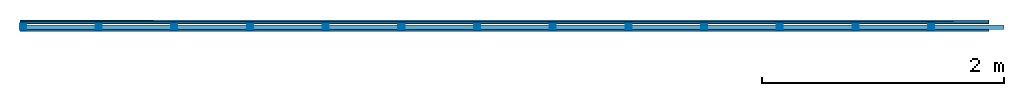
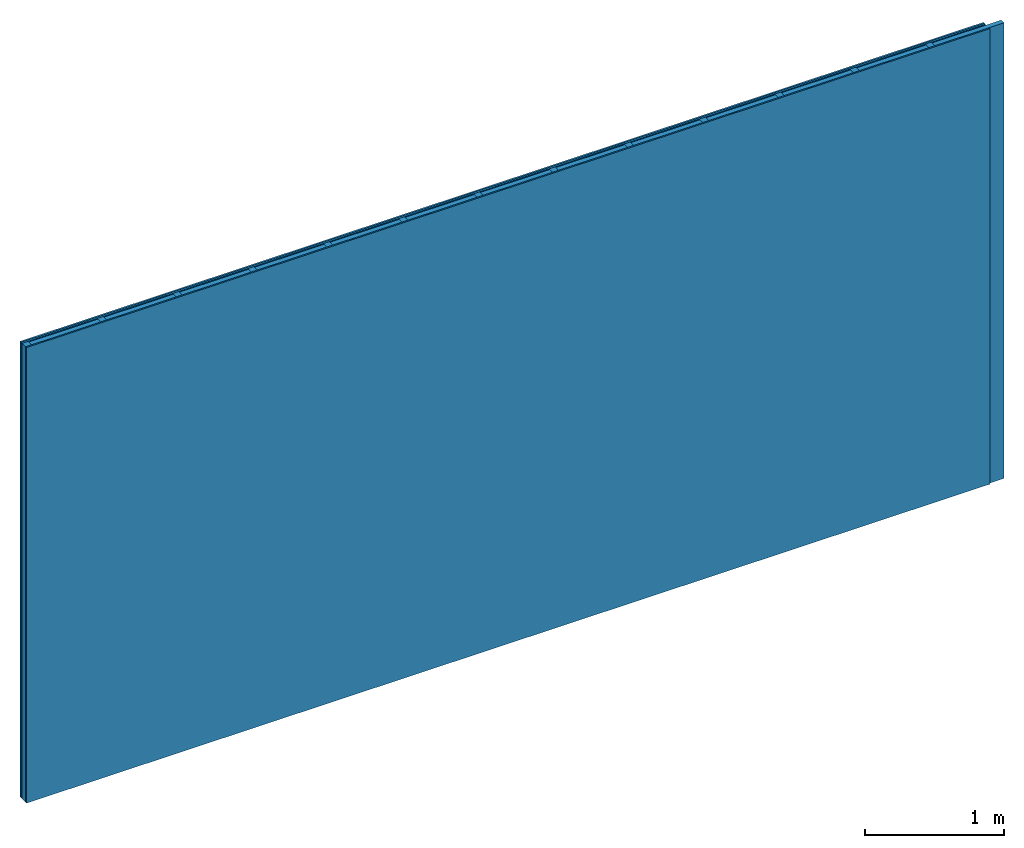
# One storey: 3 plates, 2 members, 1 element without a shape of its own.
"""IFC4 building model written with IfcOpenShell, lengths in metres."""

from ifc_helpers import new_model, si_unit, derived_unit, direction, frame, frame_2d, origin, origin_with_axes, place, context, project, spatial, rectangle, extrude, material, layer, layer_set, type_object, element, aggregate, save


model = new_model("IFC4")

# Units and contexts
plan_context = context("Plan", 3, precision=1e-05, world=origin(), true_north=direction((0.0, 1.0)))
model_context = context("Model", 3, precision=1e-05, world=origin(), true_north=direction((0.0, 1.0)))
ifc_project = project(units=[si_unit("LENGTHUNIT", "METRE"), derived_unit("SOUNDPRESSUREUNIT", [(si_unit("PRESSUREUNIT", "PASCAL", prefix="MICRO"), 0)]), si_unit("ENERGYUNIT", "JOULE", prefix="MEGA"), si_unit("MASSUNIT", "GRAM", prefix="KILO"), derived_unit("THERMALTRANSMITTANCEUNIT", [(si_unit("POWERUNIT", "WATT"), 1), (si_unit("AREAUNIT", "SQUARE_METRE"), -1), (si_unit("THERMODYNAMICTEMPERATUREUNIT", "KELVIN"), -1)]), derived_unit("AREADENSITYUNIT", [(si_unit("MASSUNIT", "GRAM", prefix="KILO"), 1), (si_unit("AREAUNIT", "SQUARE_METRE"), -1)]), derived_unit("USERDEFINED", [(si_unit("ENERGYUNIT", "JOULE", prefix="MEGA"), 1), (si_unit("AREAUNIT", "SQUARE_METRE"), -1)])], contexts=[plan_context, model_context])

# Site, building, storey
site = spatial("IfcSite", under=ifc_project)
building_placement = place(None, origin())
building = spatial("IfcBuilding", under=site, at=building_placement)
storey_placement = place(building_placement, origin())
storey = spatial("IfcBuildingStorey", under=building, at=storey_placement)

# Wall, members, plates
ifc_material_1 = material(Name="joints", Category="04.017")
ifc_layer_1 = layer(ifc_material_1, 0.0, Name="Surface")
ifc_material_2 = material(Name="Phone PLUS TRI", Category="03.013")
ifc_layer_2 = layer(ifc_material_2, 0.015, Name="2nd layer")
ifc_layer_3 = layer(ifc_material_2, 0.015, Name="1st layer")
ifc_material_3 = material(Name="of the art")
ifc_layer_4 = layer(ifc_material_3, 0.0, Name="Bond")
ifc_layer_5 = layer(None, 0.05, Name="Support")
ifc_layer_6 = layer(ifc_material_3, 0.0, Name="Bond")
ifc_material_4 = material(Name="Plasterboard type A", Category="03.008")
ifc_layer_7 = layer(ifc_material_4, 0.0125, Name="1st layer")
ifc_layer_8 = layer(ifc_material_1, 0.0, Name="Surface")
ifc_layer_set = layer_set([ifc_layer_1, ifc_layer_2, ifc_layer_3, ifc_layer_4, ifc_layer_5, ifc_layer_6, ifc_layer_7, ifc_layer_8])
wall_type = type_object("IfcWallType", Name="C0459", PredefinedType="NOTDEFINED", material=ifc_layer_set)
wall_placement = place(None, frame((0.0, 0.0, 0.0), z_axis=(0.0, -1.0, 0.0), x_axis=(1.0, 0.0, 0.0)))
wall = element("IfcWall", 1, at=wall_placement, inside=storey, type_object=wall_type, material=ifc_layer_set, Name="Wall #1")
ifc_material_5 = material()
member_1_placement = place(wall_placement, origin())
member_1 = element("IfcMember", 2, at=member_1_placement, material=ifc_material_5, Name="Support", context=plan_context, shape_type="SweptSolid", body=[
    extrude(rectangle(XDim=0.05, YDim=0.05, at=frame_2d((0.025, 0.025), x_axis=(1.0, 0.0))), frame((0.0, 4.0, 0.03), z_axis=(0.0, -1.0, 0.0), x_axis=(1.0, 0.0, 0.0)), (0.0, 0.0, 1.0), 4.0),
    extrude(rectangle(XDim=0.05, YDim=0.05, at=frame_2d((0.025, 0.025), x_axis=(1.0, 0.0))), frame((0.625, 4.0, 0.03), z_axis=(0.0, -1.0, 0.0), x_axis=(1.0, 0.0, 0.0)), (0.0, 0.0, 1.0), 4.0),
    extrude(rectangle(XDim=0.05, YDim=0.05, at=frame_2d((0.025, 0.025), x_axis=(1.0, 0.0))), frame((1.25, 4.0, 0.03), z_axis=(0.0, -1.0, 0.0), x_axis=(1.0, 0.0, 0.0)), (0.0, 0.0, 1.0), 4.0),
    extrude(rectangle(XDim=0.05, YDim=0.05, at=frame_2d((0.025, 0.025), x_axis=(1.0, 0.0))), frame((1.875, 4.0, 0.03), z_axis=(0.0, -1.0, 0.0), x_axis=(1.0, 0.0, 0.0)), (0.0, 0.0, 1.0), 4.0),
    extrude(rectangle(XDim=0.05, YDim=0.05, at=frame_2d((0.025, 0.025), x_axis=(1.0, 0.0))), frame((2.5, 4.0, 0.03), z_axis=(0.0, -1.0, 0.0), x_axis=(1.0, 0.0, 0.0)), (0.0, 0.0, 1.0), 4.0),
    extrude(rectangle(XDim=0.05, YDim=0.05, at=frame_2d((0.025, 0.025), x_axis=(1.0, 0.0))), frame((3.125, 4.0, 0.03), z_axis=(0.0, -1.0, 0.0), x_axis=(1.0, 0.0, 0.0)), (0.0, 0.0, 1.0), 4.0),
    extrude(rectangle(XDim=0.05, YDim=0.05, at=frame_2d((0.025, 0.025), x_axis=(1.0, 0.0))), frame((3.75, 4.0, 0.03), z_axis=(0.0, -1.0, 0.0), x_axis=(1.0, 0.0, 0.0)), (0.0, 0.0, 1.0), 4.0),
    extrude(rectangle(XDim=0.05, YDim=0.05, at=frame_2d((0.025, 0.025), x_axis=(1.0, 0.0))), frame((4.375, 4.0, 0.03), z_axis=(0.0, -1.0, 0.0), x_axis=(1.0, 0.0, 0.0)), (0.0, 0.0, 1.0), 4.0),
    extrude(rectangle(XDim=0.05, YDim=0.05, at=frame_2d((0.025, 0.025), x_axis=(1.0, 0.0))), frame((5.0, 4.0, 0.03), z_axis=(0.0, -1.0, 0.0), x_axis=(1.0, 0.0, 0.0)), (0.0, 0.0, 1.0), 4.0),
    extrude(rectangle(XDim=0.05, YDim=0.05, at=frame_2d((0.025, 0.025), x_axis=(1.0, 0.0))), frame((5.625, 4.0, 0.03), z_axis=(0.0, -1.0, 0.0), x_axis=(1.0, 0.0, 0.0)), (0.0, 0.0, 1.0), 4.0),
    extrude(rectangle(XDim=0.05, YDim=0.05, at=frame_2d((0.025, 0.025), x_axis=(1.0, 0.0))), frame((6.25, 4.0, 0.03), z_axis=(0.0, -1.0, 0.0), x_axis=(1.0, 0.0, 0.0)), (0.0, 0.0, 1.0), 4.0),
    extrude(rectangle(XDim=0.05, YDim=0.05, at=frame_2d((0.025, 0.025), x_axis=(1.0, 0.0))), frame((6.875, 4.0, 0.03), z_axis=(0.0, -1.0, 0.0), x_axis=(1.0, 0.0, 0.0)), (0.0, 0.0, 1.0), 4.0),
    extrude(rectangle(XDim=0.05, YDim=0.05, at=frame_2d((0.025, 0.025), x_axis=(1.0, 0.0))), frame((7.5, 4.0, 0.03), z_axis=(0.0, -1.0, 0.0), x_axis=(1.0, 0.0, 0.0)), (0.0, 0.0, 1.0), 4.0),
])
ifc_material_6 = material()
member_2_placement = place(wall_placement, origin())
member_2 = element("IfcMember", 3, at=member_2_placement, material=ifc_material_6, Name="Cavity", context=plan_context, shape_type="SweptSolid", body=[
    extrude(rectangle(XDim=0.575, YDim=0.04, at=frame_2d((0.2875, 0.02), x_axis=(1.0, 0.0))), frame((0.05, 4.0, 0.04), z_axis=(0.0, -1.0, 0.0), x_axis=(1.0, 0.0, 0.0)), (0.0, 0.0, 1.0), 4.0),
    extrude(rectangle(XDim=0.575, YDim=0.04, at=frame_2d((0.2875, 0.02), x_axis=(1.0, 0.0))), frame((0.675, 4.0, 0.04), z_axis=(0.0, -1.0, 0.0), x_axis=(1.0, 0.0, 0.0)), (0.0, 0.0, 1.0), 4.0),
    extrude(rectangle(XDim=0.575, YDim=0.04, at=frame_2d((0.2875, 0.02), x_axis=(1.0, 0.0))), frame((1.3, 4.0, 0.04), z_axis=(0.0, -1.0, 0.0), x_axis=(1.0, 0.0, 0.0)), (0.0, 0.0, 1.0), 4.0),
    extrude(rectangle(XDim=0.575, YDim=0.04, at=frame_2d((0.2875, 0.02), x_axis=(1.0, 0.0))), frame((1.925, 4.0, 0.04), z_axis=(0.0, -1.0, 0.0), x_axis=(1.0, 0.0, 0.0)), (0.0, 0.0, 1.0), 4.0),
    extrude(rectangle(XDim=0.575, YDim=0.04, at=frame_2d((0.2875, 0.02), x_axis=(1.0, 0.0))), frame((2.55, 4.0, 0.04), z_axis=(0.0, -1.0, 0.0), x_axis=(1.0, 0.0, 0.0)), (0.0, 0.0, 1.0), 4.0),
    extrude(rectangle(XDim=0.575, YDim=0.04, at=frame_2d((0.2875, 0.02), x_axis=(1.0, 0.0))), frame((3.175, 4.0, 0.04), z_axis=(0.0, -1.0, 0.0), x_axis=(1.0, 0.0, 0.0)), (0.0, 0.0, 1.0), 4.0),
    extrude(rectangle(XDim=0.575, YDim=0.04, at=frame_2d((0.2875, 0.02), x_axis=(1.0, 0.0))), frame((3.8, 4.0, 0.04), z_axis=(0.0, -1.0, 0.0), x_axis=(1.0, 0.0, 0.0)), (0.0, 0.0, 1.0), 4.0),
    extrude(rectangle(XDim=0.575, YDim=0.04, at=frame_2d((0.2875, 0.02), x_axis=(1.0, 0.0))), frame((4.425, 4.0, 0.04), z_axis=(0.0, -1.0, 0.0), x_axis=(1.0, 0.0, 0.0)), (0.0, 0.0, 1.0), 4.0),
    extrude(rectangle(XDim=0.575, YDim=0.04, at=frame_2d((0.2875, 0.02), x_axis=(1.0, 0.0))), frame((5.05, 4.0, 0.04), z_axis=(0.0, -1.0, 0.0), x_axis=(1.0, 0.0, 0.0)), (0.0, 0.0, 1.0), 4.0),
    extrude(rectangle(XDim=0.575, YDim=0.04, at=frame_2d((0.2875, 0.02), x_axis=(1.0, 0.0))), frame((5.675, 4.0, 0.04), z_axis=(0.0, -1.0, 0.0), x_axis=(1.0, 0.0, 0.0)), (0.0, 0.0, 1.0), 4.0),
    extrude(rectangle(XDim=0.575, YDim=0.04, at=frame_2d((0.2875, 0.02), x_axis=(1.0, 0.0))), frame((6.3, 4.0, 0.04), z_axis=(0.0, -1.0, 0.0), x_axis=(1.0, 0.0, 0.0)), (0.0, 0.0, 1.0), 4.0),
    extrude(rectangle(XDim=0.575, YDim=0.04, at=frame_2d((0.2875, 0.02), x_axis=(1.0, 0.0))), frame((6.925, 4.0, 0.04), z_axis=(0.0, -1.0, 0.0), x_axis=(1.0, 0.0, 0.0)), (0.0, 0.0, 1.0), 4.0),
    extrude(rectangle(XDim=0.575, YDim=0.04, at=frame_2d((0.2875, 0.02), x_axis=(1.0, 0.0))), frame((7.55, 4.0, 0.04), z_axis=(0.0, -1.0, 0.0), x_axis=(1.0, 0.0, 0.0)), (0.0, 0.0, 1.0), 4.0),
])
plate_1_placement = place(wall_placement, origin())
plate_1 = element("IfcPlate", 4, at=plate_1_placement, material=ifc_material_2, Name="2nd layer", context=plan_context, shape_type="SweptSolid", body=[
    extrude(rectangle(XDim=8.0, YDim=4.0, at=frame_2d((4.0, 2.0), x_axis=(1.0, 0.0))), origin_with_axes(), (0.0, 0.0, 1.0), 0.015),
])
plate_2_placement = place(wall_placement, origin())
plate_2 = element("IfcPlate", 5, at=plate_2_placement, material=ifc_material_2, Name="1st layer", context=plan_context, shape_type="SweptSolid", body=[
    extrude(rectangle(XDim=8.0, YDim=4.0, at=frame_2d((4.0, 2.0), x_axis=(1.0, 0.0))), frame((0.0, 0.0, 0.015), z_axis=(0.0, 0.0, 1.0), x_axis=(1.0, 0.0, 0.0)), (0.0, 0.0, 1.0), 0.015),
])
plate_3_placement = place(wall_placement, origin())
plate_3 = element("IfcPlate", 6, at=plate_3_placement, material=ifc_material_4, Name="1st layer", context=plan_context, shape_type="SweptSolid", body=[
    extrude(rectangle(XDim=8.0, YDim=4.0, at=frame_2d((4.0, 2.0), x_axis=(1.0, 0.0))), frame((0.0, 0.0, 0.08), z_axis=(0.0, 0.0, 1.0), x_axis=(1.0, 0.0, 0.0)), (0.0, 0.0, 1.0), 0.0125),
])
aggregate(wall, [plate_1, plate_2, member_1, member_2, plate_3])

save(model, "model.ifc")
